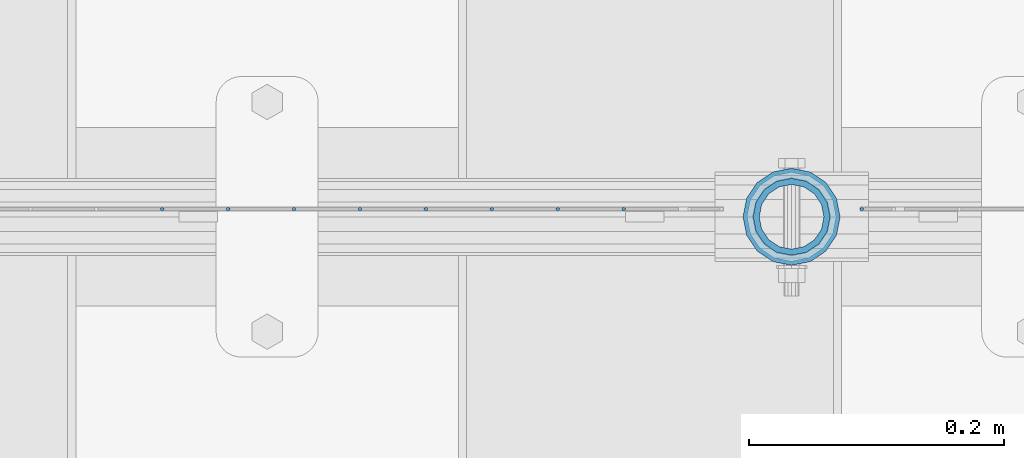
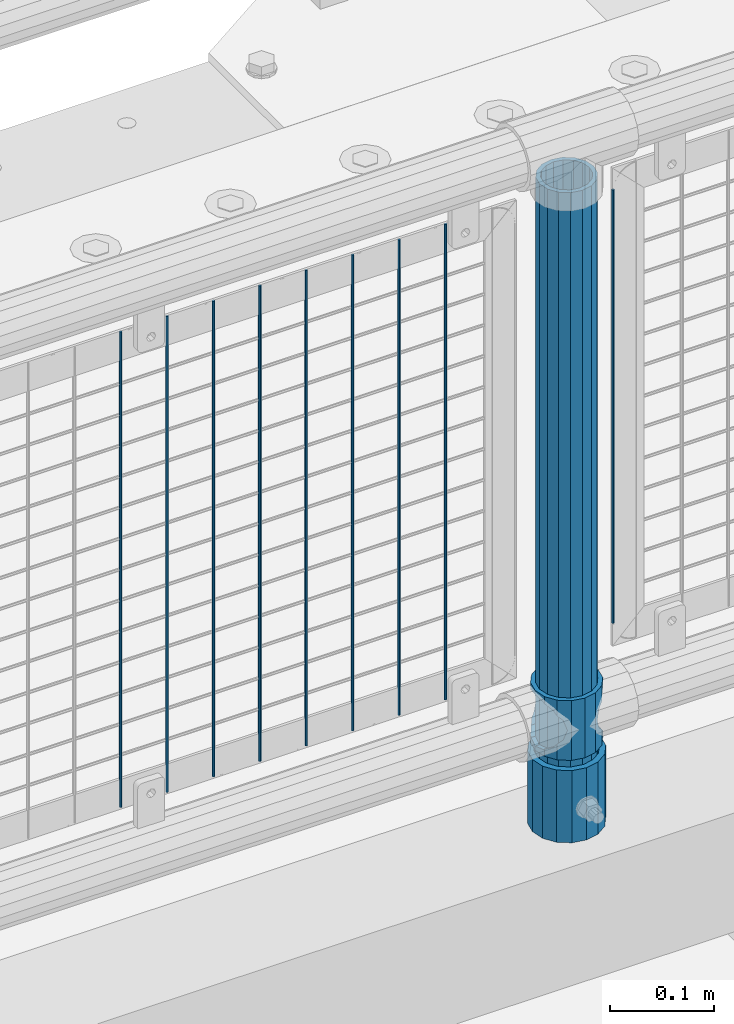
# One storey, part 70 of 193: 12 columns.
"""IFC2X3 building model written with IfcOpenShell, lengths in millimetres."""

from ifc_helpers import new_model, si_unit, frame, origin_with_axes, place, context, subcontext, project, spatial, faceted_brep, material, type_object, element, save


model = new_model("IFC2X3")

# Units and contexts
model_context = context("Model", 3, precision=1e-05, world=origin_with_axes())
body_context = subcontext(model_context, "Body", "Model", "MODEL_VIEW")
ifc_project = project(units=[si_unit("LENGTHUNIT", "METRE", prefix="MILLI"), si_unit("AREAUNIT", "SQUARE_METRE"), si_unit("VOLUMEUNIT", "CUBIC_METRE"), si_unit("MASSUNIT", "GRAM", prefix="KILO"), si_unit("TIMEUNIT", "SECOND"), si_unit("PLANEANGLEUNIT", "RADIAN"), si_unit("SOLIDANGLEUNIT", "STERADIAN"), si_unit("THERMODYNAMICTEMPERATUREUNIT", "DEGREE_CELSIUS"), si_unit("LUMINOUSINTENSITYUNIT", "LUMEN")], contexts=[model_context])

# Site, building, storey
site_placement = place(None, origin_with_axes())
site = spatial("IfcSite", under=ifc_project, at=site_placement, CompositionType="ELEMENT")
building_placement = place(site_placement, origin_with_axes())
building = spatial("IfcBuilding", under=site, at=building_placement, Name="Standard", CompositionType="ELEMENT")
storey_placement = place(building_placement, origin_with_axes())
storey = spatial("IfcBuildingStorey", under=building, at=storey_placement, Name="Undefined", CompositionType="ELEMENT", Elevation=0.0)

# Columns
ifc_material_1 = material(Name="Misc_Undefined")
column_type_1 = type_object("IfcColumnType", PredefinedType="NOTDEFINED")
column_1_placement = place(storey_placement, frame((-33539.0, 28664.5, 263.020000000001), z_axis=(-1.0, 0.0, 0.0), x_axis=(0.0, 0.0, 1.0)))
element("IfcColumn", 1, at=column_1_placement, inside=storey, type_object=column_type_1, material=ifc_material_1, context=body_context, shape_type="Brep", body=[
    faceted_brep([(56.6106908090114, 21.46069080901, -21.46069080901), (56.6106908090114, 21.46069080901, -27.1226768591041), (61.9623795176744, 13.4513226476338, -32.4743655677703), (63.1897438117172, 11.614442172282, -32.8397438117245), (63.1897438117172, 11.614442172282, -28.0397438117179), (46.7644421722801, 28.0397438117179, -11.614442172282), (46.7644421722801, 28.0397438117179, -20.0882031229849), (51.5310424080006, 24.8548033587067, -24.8548033587067), (35.1500000000015, 30.35, 0.0), (35.1499999999996, 30.3499999999985, -16.6306603983685), (23.5355578277192, 28.0397438117179, -11.614442172282), (23.5355578277192, 28.0397438117179, -20.0882031229849), (13.6893091909879, 21.46069080901, -21.46069080901), (13.6893091909879, 21.46069080901, -27.1226768591041), (18.7689575919987, 24.8548033587067, -24.8548033587067), (7.11025618828211, 11.614442172282, -28.0397438117179), (7.11025618828211, 11.614442172282, -32.8397438117245), (8.33762048232262, 13.4513226476338, -32.4743655677703), (4.79999999999961, 0.0, -30.3499999999985), (4.79999999999961, 0.0, -35.1500000000015), (7.11025618828211, -11.614442172282, -28.0397438117179), (7.11025618828211, -11.614442172282, -32.8397438117172), (13.6893091909879, -21.46069080901, -21.46069080901), (13.6893091909879, -21.46069080901, -27.1226768591114), (8.33762048232484, -13.4513226476338, -32.4743655677703), (23.5355578277191, -28.0397438117179, -11.614442172282), (23.5355578277191, -28.0397438117179, -20.0882031229812), (18.7689575919921, -24.8548033587067, -24.8548033587067), (35.1500000000015, -30.35, 0.0), (35.1499999999996, -30.3499999999985, -16.6306603983721), (46.7644421722801, -28.0397438117179, -11.614442172282), (46.7644421722801, -28.0397438117179, -20.0882031229812), (56.6106908090114, -21.46069080901, -21.46069080901), (56.6106908090114, -21.46069080901, -27.1226768591114), (51.5310424080006, -24.8548033587067, -24.8548033587067), (63.1897438117172, -11.614442172282, -28.0397438117179), (63.1897438117172, -11.614442172282, -32.8397438117172), (61.9623795176767, -13.4513226476338, -32.4743655677703), (65.4999999999997, 0.0, -30.3499999999985), (65.4999999999997, 0.0, -35.1500000000015), (0.0, -28.0397438117179, -11.614442172282), (0.0, -30.3499999999985, 0.0), (0.0, -21.46069080901, -21.46069080901), (0.0, -11.614442172282, -28.0397438117179), (0.0, 0.0, -30.3499999999985), (0.0, 11.614442172282, -28.0397438117179), (0.0, 21.46069080901, -21.46069080901), (0.0, 28.0397438117179, -11.614442172282), (0.0, 30.3499999999985, 0.0), (0.0, 28.0397438117179, 11.614442172282), (23.5355578277192, 28.0397438117179, 11.614442172282), (0.0, 21.46069080901, 21.46069080901), (13.6893091909879, 21.46069080901, 21.46069080901), (0.0, 11.614442172282, 28.0397438117179), (7.11025618828211, 11.614442172282, 28.0397438117179), (0.0, 0.0, 30.3499999999985), (4.79999999999961, 0.0, 30.3499999999985), (0.0, -11.614442172282, 28.0397438117179), (7.11025618828205, -11.614442172282, 28.0397438117179), (0.0, -21.46069080901, 21.46069080901), (13.6893091909879, -21.46069080901, 21.46069080901), (0.0, -28.0397438117179, 11.614442172282), (23.5355578277191, -28.0397438117179, 11.614442172282), (0.0, -32.4743655677703, 13.4513226476338), (0.0, -35.1500000000015, 0.0), (70.2999999999993, -35.1500000000015, 0.0), (70.2999999999993, -32.4743655677703, 13.4513226476338), (0.0, 13.4513226476338, -32.4743655677703), (0.0, 24.8548033587067, -24.8548033587067), (0.0, 0.0, -35.1500000000015), (0.0, -13.4513226476338, -32.4743655677703), (0.0, -24.8548033587067, -24.8548033587067), (0.0, -24.8548033587067, 24.8548033587067), (0.0, -13.4513226476338, 32.4743655677703), (0.0, 0.0, 35.1500000000015), (0.0, 13.4513226476338, 32.4743655677703), (0.0, 24.8548033587067, 24.8548033587067), (0.0, 32.4743655677703, 13.4513226476338), (0.0, 35.1500000000015, 0.0), (0.0, 32.4743655677703, -13.4513226476338), (0.0, -32.4743655677703, -13.4513226476338), (70.2999999999993, 32.4743655677703, 13.4513226476338), (70.2999999999993, 35.1500000000015, 0.0), (70.2999999999993, 32.4743655677703, -13.4513226476338), (70.2999999999993, 24.8548033587067, -24.8548033587067), (70.2999999999993, 13.4513226476338, -32.4743655677703), (70.2999999999993, 0.0, -35.1500000000015), (70.2999999999993, -13.4513226476338, -32.4743655677703), (70.2999999999993, -24.8548033587067, -24.8548033587067), (70.2999999999993, -32.4743655677703, -13.4513226476338), (70.2999999999993, 28.0397438117179, 11.614442172282), (70.2999999999993, 21.46069080901, 21.46069080901), (56.6106908090114, 21.46069080901, 21.46069080901), (46.7644421722801, 28.0397438117179, 11.614442172282), (70.2999999999993, 11.614442172282, 28.0397438117179), (63.1897438117172, 11.614442172282, 28.0397438117179), (70.2999999999993, 0.0, 30.3499999999985), (65.4999999999997, 0.0, 30.3499999999985), (70.2999999999993, -11.614442172282, 28.0397438117179), (63.1897438117172, -11.614442172282, 28.0397438117179), (70.2999999999993, -21.46069080901, 21.46069080901), (56.6106908090114, -21.46069080901, 21.46069080901), (70.2999999999993, -28.0397438117179, 11.614442172282), (46.7644421722801, -28.0397438117179, 11.614442172282), (70.2999999999993, -11.614442172282, -28.0397438117179), (70.2999999999993, 0.0, -30.3499999999985), (70.2999999999993, -21.46069080901, -21.46069080901), (70.2999999999993, -28.0397438117179, -11.614442172282), (70.2999999999993, -30.3499999999985, 0.0), (70.2999999999993, 24.8548033587067, 24.8548033587067), (70.2999999999993, 13.4513226476338, 32.4743655677703), (70.2999999999993, 0.0, 35.1500000000015), (70.2999999999993, -13.4513226476338, 32.4743655677703), (70.2999999999993, -24.8548033587067, 24.8548033587067), (70.2999999999993, 30.3499999999985, 0.0), (70.2999999999993, 28.0397438117179, -11.614442172282), (70.2999999999993, 21.46069080901, -21.46069080901), (70.2999999999993, 11.614442172282, -28.0397438117179), (61.9623795176742, 13.4513226476338, 32.4743655677703), (51.5310424080006, 24.8548033587067, 24.8548033587067), (56.6106908090114, 21.46069080901, 27.1226768591077), (65.4999999999997, 0.0, 35.1500000000015), (63.1897438117172, 11.614442172282, 32.8397438117136), (63.1897438117172, -11.614442172282, 32.8397438117136), (61.9623795176767, -13.4513226476338, 32.4743655677703), (56.6106908090114, -21.46069080901, 27.1226768591041), (51.5310424080006, -24.8548033587067, 24.8548033587067), (18.7689575919921, -24.8548033587067, 24.8548033587067), (46.7644421722801, -28.0397438117179, 20.0882031229812), (35.1499999999996, -30.3499999999985, 16.6306603983685), (23.5355578277191, -28.0397438117179, 20.0882031229812), (8.33762048232512, -13.4513226476338, 32.4743655677703), (13.6893091909879, -21.46069080901, 27.1226768591041), (4.79999999999961, 0.0, 35.1500000000015), (7.11025618828205, -11.614442172282, 32.8397438117136), (7.11025618828211, 11.614442172282, 32.8397438117136), (8.3376204823229, 13.4513226476338, 32.4743655677703), (13.6893091909879, 21.46069080901, 27.1226768591077), (18.7689575919987, 24.8548033587067, 24.8548033587067), (23.5355578277192, 28.0397438117179, 20.0882031229739), (35.1499999999996, 30.3499999999985, 16.6306603983576), (46.7644421722801, 28.0397438117179, 20.0882031229739)], [[[0, 1, 2, 3, 4]], [[5, 6, 7, 1, 0]], [[8, 9, 6, 5]], [[10, 11, 9, 8]], [[12, 13, 14, 11, 10]], [[15, 16, 17, 13, 12]], [[18, 19, 16, 15]], [[20, 21, 19, 18]], [[22, 23, 24, 21, 20]], [[25, 26, 27, 23, 22]], [[28, 29, 26, 25]], [[30, 31, 29, 28]], [[32, 33, 34, 31, 30]], [[35, 36, 37, 33, 32]], [[38, 39, 36, 35]], [[4, 3, 39, 38]], [[40, 41, 28, 25]], [[42, 40, 25, 22]], [[43, 42, 22, 20]], [[44, 43, 20, 18]], [[45, 44, 18, 15]], [[46, 45, 15, 12]], [[47, 46, 12, 10]], [[48, 47, 10, 8]], [[49, 48, 8, 50]], [[51, 49, 50, 52]], [[53, 51, 52, 54]], [[55, 53, 54, 56]], [[57, 55, 56, 58]], [[59, 57, 58, 60]], [[61, 59, 60, 62]], [[41, 61, 62, 28]], [[63, 64, 65, 66]], [[17, 67, 68, 14, 13]], [[19, 69, 67, 17, 16]], [[70, 69, 19, 21, 24]], [[71, 70, 24, 23, 27]], [[63, 72, 73, 74, 75, 76, 77, 78, 79, 68, 67, 69, 70, 71, 80, 64], [40, 42, 43, 44, 45, 46, 47, 48, 49, 51, 53, 55, 57, 59, 61, 41]], [[78, 77, 81, 82]], [[79, 78, 82, 83]], [[14, 68, 79, 83, 84, 7, 6, 9, 11]], [[84, 85, 2, 1, 7]], [[85, 86, 39, 3, 2]], [[37, 87, 88, 34, 33]], [[39, 86, 87, 37, 36]], [[34, 88, 89, 80, 71, 27, 26, 29, 31]], [[64, 80, 89, 65]], [[90, 91, 92, 93]], [[91, 94, 95, 92]], [[94, 96, 97, 95]], [[96, 98, 99, 97]], [[98, 100, 101, 99]], [[100, 102, 103, 101]], [[104, 105, 38, 35]], [[106, 104, 35, 32]], [[107, 106, 32, 30]], [[108, 107, 30, 28]], [[102, 108, 28, 103]], [[88, 87, 86, 85, 84, 83, 82, 81, 109, 110, 111, 112, 113, 66, 65, 89], [100, 98, 96, 94, 91, 90, 114, 115, 116, 117, 105, 104, 106, 107, 108, 102]], [[118, 110, 109, 119, 120]], [[121, 111, 110, 118, 122]], [[112, 111, 121, 123, 124]], [[113, 112, 124, 125, 126]], [[127, 72, 63, 66, 113, 126, 128, 129, 130]], [[131, 73, 72, 127, 132]], [[133, 74, 73, 131, 134]], [[75, 74, 133, 135, 136]], [[76, 75, 136, 137, 138]], [[119, 109, 81, 77, 76, 138, 139, 140, 141]], [[92, 120, 119, 141, 93]], [[95, 122, 118, 120, 92]], [[97, 121, 122, 95]], [[99, 123, 121, 97]], [[101, 125, 124, 123, 99]], [[103, 128, 126, 125, 101]], [[28, 129, 128, 103]], [[62, 130, 129, 28]], [[60, 132, 127, 130, 62]], [[58, 134, 131, 132, 60]], [[56, 133, 134, 58]], [[54, 135, 133, 56]], [[52, 137, 136, 135, 54]], [[50, 139, 138, 137, 52]], [[8, 140, 139, 50]], [[93, 141, 140, 8]], [[114, 90, 93, 8]], [[115, 114, 8, 5]], [[116, 115, 5, 0]], [[117, 116, 0, 4]], [[105, 117, 4, 38]]]),
])
ifc_material_2 = material()
column_type_2 = type_object("IfcColumnType", PredefinedType="NOTDEFINED")
column_2_placement = place(storey_placement, frame((-33539.0, 28664.5, 168.02), z_axis=(-1.0, 0.0, 0.0), x_axis=(0.0, 0.0, 1.0)))
element("IfcColumn", 2, at=column_2_placement, inside=storey, type_object=column_type_2, material=ifc_material_2, context=body_context, shape_type="Brep", body=[
    faceted_brep([(0.0, -25.3499999999985, 0.0), (0.0, -23.4203461491597, 9.70102501045403), (760.0, -23.4203461491597, 9.70102501045403), (760.0, -25.3499999999985, 0.0), (0.0, -17.9251569030785, 17.9251569030785), (760.0, -17.9251569030785, 17.9251569030785), (0.0, -9.70102501045403, 23.4203461491597), (760.0, -9.70102501045403, 23.4203461491597), (0.0, 0.0, 25.3499999999985), (760.0, 0.0, 25.3499999999985), (0.0, 9.70102501045403, 23.4203461491597), (760.0, 9.70102501045403, 23.4203461491597), (0.0, 17.9251569030785, 17.9251569030785), (760.0, 17.9251569030785, 17.9251569030785), (0.0, 23.4203461491597, 9.70102501045403), (760.0, 23.4203461491597, 9.70102501045403), (0.0, 25.3499999999985, 0.0), (760.0, 25.3499999999985, 0.0), (0.0, 23.4203461491597, -9.70102501045403), (760.0, 23.4203461491597, -9.70102501045403), (0.0, 17.9251569030785, -17.9251569030785), (760.0, 17.9251569030785, -17.9251569030785), (0.0, 9.70102501045403, -23.4203461491597), (760.0, 9.70102501045403, -23.4203461491597), (0.0, 0.0, -25.3499999999985), (760.0, 0.0, -25.3499999999985), (0.0, -9.70102501045403, -23.4203461491597), (760.0, -9.70102501045403, -23.4203461491597), (0.0, -17.9251569030785, -17.9251569030785), (760.0, -17.9251569030785, -17.9251569030785), (0.0, -23.4203461491597, -9.70102501045403), (760.0, -23.4203461491597, -9.70102501045403), (0.0, -30.1500000000015, 0.0), (0.0, -27.8549679052157, -11.5379054858058), (760.0, -27.8549679052157, -11.5379054858058), (760.0, -30.1500000000015, 0.0), (0.0, -21.3192694527752, -21.3192694527752), (760.0, -21.3192694527752, -21.3192694527752), (0.0, -11.5379054858058, -27.8549679052157), (760.0, -11.5379054858058, -27.8549679052157), (0.0, 0.0, -30.1500000000015), (760.0, 0.0, -30.1500000000015), (0.0, 11.5379054858058, -27.8549679052157), (760.0, 11.5379054858058, -27.8549679052157), (0.0, 21.3192694527752, -21.3192694527752), (760.0, 21.3192694527752, -21.3192694527752), (0.0, 27.8549679052157, -11.5379054858058), (760.0, 27.8549679052157, -11.5379054858058), (0.0, 30.1500000000015, 0.0), (760.0, 30.1500000000015, 0.0), (0.0, 27.8549679052157, 11.5379054858058), (760.0, 27.8549679052157, 11.5379054858058), (0.0, 21.3192694527752, 21.3192694527752), (760.0, 21.3192694527752, 21.3192694527752), (0.0, 11.5379054858058, 27.8549679052157), (760.0, 11.5379054858058, 27.8549679052157), (0.0, 0.0, 30.1500000000015), (760.0, 0.0, 30.1500000000015), (0.0, -11.5379054858058, 27.8549679052157), (760.0, -11.5379054858058, 27.8549679052157), (0.0, -21.3192694527752, 21.3192694527752), (760.0, -21.3192694527752, 21.3192694527752), (0.0, -27.8549679052157, 11.5379054858058), (760.0, -27.8549679052157, 11.5379054858058)], [[[0, 1, 2, 3]], [[1, 4, 5, 2]], [[4, 6, 7, 5]], [[6, 8, 9, 7]], [[8, 10, 11, 9]], [[10, 12, 13, 11]], [[12, 14, 15, 13]], [[14, 16, 17, 15]], [[16, 18, 19, 17]], [[18, 20, 21, 19]], [[20, 22, 23, 21]], [[22, 24, 25, 23]], [[24, 26, 27, 25]], [[26, 28, 29, 27]], [[28, 30, 31, 29]], [[30, 0, 3, 31]], [[32, 33, 34, 35]], [[33, 36, 37, 34]], [[36, 38, 39, 37]], [[38, 40, 41, 39]], [[40, 42, 43, 41]], [[42, 44, 45, 43]], [[44, 46, 47, 45]], [[46, 48, 49, 47]], [[48, 50, 51, 49]], [[50, 52, 53, 51]], [[52, 54, 55, 53]], [[54, 56, 57, 55]], [[56, 58, 59, 57]], [[58, 60, 61, 59]], [[60, 62, 63, 61]], [[62, 32, 35, 63]], [[37, 39, 41, 43, 45, 47, 49, 51, 53, 55, 57, 59, 61, 63, 35, 34], [5, 7, 9, 11, 13, 15, 17, 19, 21, 23, 25, 27, 29, 31, 3, 2]], [[62, 60, 58, 56, 54, 52, 50, 48, 46, 44, 42, 40, 38, 36, 33, 32], [30, 28, 26, 24, 22, 20, 18, 16, 14, 12, 10, 8, 6, 4, 1, 0]]]),
])
column_type_3 = type_object("IfcColumnType", PredefinedType="NOTDEFINED")
column_3_placement = place(storey_placement, frame((-33539.0, 28664.5, 168.02), z_axis=(0.0, 1.0, 0.0), x_axis=(0.0, 0.0, 1.0)))
element("IfcColumn", 3, at=column_3_placement, inside=storey, type_object=column_type_3, material=ifc_material_2, context=body_context, shape_type="Brep", body=[
    faceted_brep([(0.0, -31.75, 0.0), (0.0, -29.3331751572332, 12.1501989775934), (85.0, -29.3331751572332, 12.1501989775934), (85.0, -31.75, 0.0), (0.0, -22.4506403026717, 22.4506403026717), (85.0, -22.4506403026717, 22.4506403026717), (0.0, -12.1501989775934, 29.3331751572332), (85.0, -12.1501989775934, 29.3331751572332), (0.0, 0.0, 31.75), (85.0, 0.0, 31.75), (0.0, 12.1501989775934, 29.3331751572332), (85.0, 12.1501989775934, 29.3331751572332), (0.0, 22.4506403026717, 22.4506403026717), (85.0, 22.4506403026717, 22.4506403026717), (0.0, 29.3331751572332, 12.1501989775934), (85.0, 29.3331751572332, 12.1501989775934), (0.0, 31.75, 0.0), (85.0, 31.75, 0.0), (0.0, 29.3331751572332, -12.1501989775934), (85.0, 29.3331751572332, -12.1501989775934), (0.0, 22.4506403026717, -22.4506403026717), (85.0, 22.4506403026717, -22.4506403026717), (0.0, 12.1501989775934, -29.3331751572332), (85.0, 12.1501989775934, -29.3331751572332), (0.0, 0.0, -31.75), (85.0, 0.0, -31.75), (0.0, -12.1501989775934, -29.3331751572332), (85.0, -12.1501989775934, -29.3331751572332), (0.0, -22.4506403026717, -22.4506403026717), (85.0, -22.4506403026717, -22.4506403026717), (0.0, -29.3331751572332, -12.1501989775934), (85.0, -29.3331751572332, -12.1501989775934), (0.0, -38.0499999999993, 0.0), (0.0, -35.1536162120537, -14.5611046014928), (85.0, -35.1536162120537, -14.5611046014928), (85.0, -38.0499999999993, 0.0), (0.0, -26.9054130241493, -26.9054130241493), (85.0, -26.9054130241493, -26.9054130241493), (0.0, -14.5611046014928, -35.1536162120537), (85.0, -14.5611046014928, -35.1536162120537), (0.0, 0.0, -38.0499999999993), (85.0, 0.0, -38.0499999999993), (0.0, 14.5611046014928, -35.1536162120537), (85.0, 14.5611046014928, -35.1536162120537), (0.0, 26.9054130241493, -26.9054130241493), (85.0, 26.9054130241493, -26.9054130241493), (0.0, 35.1536162120537, -14.5611046014928), (85.0, 35.1536162120537, -14.5611046014928), (0.0, 38.0499999999993, 0.0), (85.0, 38.0499999999993, 0.0), (0.0, 35.1536162120537, 14.5611046014928), (85.0, 35.1536162120537, 14.5611046014928), (0.0, 26.9054130241493, 26.9054130241493), (85.0, 26.9054130241493, 26.9054130241493), (0.0, 14.5611046014928, 35.1536162120537), (85.0, 14.5611046014928, 35.1536162120537), (0.0, 0.0, 38.0499999999993), (85.0, 0.0, 38.0499999999993), (0.0, -14.5611046014928, 35.1536162120537), (85.0, -14.5611046014928, 35.1536162120537), (0.0, -26.9054130241493, 26.9054130241493), (85.0, -26.9054130241493, 26.9054130241493), (0.0, -35.1536162120537, 14.5611046014928), (85.0, -35.1536162120537, 14.5611046014928)], [[[0, 1, 2, 3]], [[1, 4, 5, 2]], [[4, 6, 7, 5]], [[6, 8, 9, 7]], [[8, 10, 11, 9]], [[10, 12, 13, 11]], [[12, 14, 15, 13]], [[14, 16, 17, 15]], [[16, 18, 19, 17]], [[18, 20, 21, 19]], [[20, 22, 23, 21]], [[22, 24, 25, 23]], [[24, 26, 27, 25]], [[26, 28, 29, 27]], [[28, 30, 31, 29]], [[30, 0, 3, 31]], [[32, 33, 34, 35]], [[33, 36, 37, 34]], [[36, 38, 39, 37]], [[38, 40, 41, 39]], [[40, 42, 43, 41]], [[42, 44, 45, 43]], [[44, 46, 47, 45]], [[46, 48, 49, 47]], [[48, 50, 51, 49]], [[50, 52, 53, 51]], [[52, 54, 55, 53]], [[54, 56, 57, 55]], [[56, 58, 59, 57]], [[58, 60, 61, 59]], [[60, 62, 63, 61]], [[62, 32, 35, 63]], [[37, 39, 41, 43, 45, 47, 49, 51, 53, 55, 57, 59, 61, 63, 35, 34], [5, 7, 9, 11, 13, 15, 17, 19, 21, 23, 25, 27, 29, 31, 3, 2]], [[62, 60, 58, 56, 54, 52, 50, 48, 46, 44, 42, 40, 38, 36, 33, 32], [30, 28, 26, 24, 22, 20, 18, 16, 14, 12, 10, 8, 6, 4, 1, 0]]]),
])
column_type_4 = type_object("IfcColumnType", Name="D3", PredefinedType="NOTDEFINED")
column_4_placement = place(storey_placement, frame((-33484.0, 28670.5, 378.020000000001), z_axis=(-1.0, 0.0, 0.0), x_axis=(0.0, 0.0, 1.0)))
element("IfcColumn", 4, at=column_4_placement, inside=storey, type_object=column_type_4, material=ifc_material_1, ObjectType="D3", context=body_context, shape_type="Brep", body=[
    faceted_brep([(0.0, -1.49999999999636, 3.63797880709171e-12), (0.0, -0.75, -1.29903810567669), (510.0, -0.75, -1.29903810567703), (510.0, -1.5, 0.0), (0.0, 0.75, -1.29903810567669), (510.0, 0.75, -1.29903810567703), (0.0, 1.50000000000364, 7.27595761418343e-12), (510.0, 1.5, 0.0), (0.0, 0.75, 1.29903810567669), (510.0, 0.75, 1.29903810567703), (0.0, -0.75, 1.29903810567669), (510.0, -0.75, 1.29903810567703)], [[[0, 1, 2, 3]], [[1, 4, 5, 2]], [[4, 6, 7, 5]], [[6, 8, 9, 7]], [[8, 10, 11, 9]], [[10, 0, 3, 11]], [[5, 7, 9, 11, 3, 2]], [[10, 8, 6, 4, 1, 0]]]),
])
for number, where, z_axis, x_axis in (
    (5, (-33670.66, 28670.5, 353.020000000001), (-1.0, 0.0, 0.0), (0.0, 0.0, 1.0)),
    (6, (-33722.315, 28670.5, 353.020000000001), (-1.0, 0.0, 0.0), (0.0, 0.0, 1.0)),
    (7, (-33773.97, 28670.5, 353.020000000001), (-1.0, 0.0, 0.0), (0.0, 0.0, 1.0)),
    (8, (-33825.625, 28670.5, 353.020000000001), (-1.0, 0.0, 0.0), (0.0, 0.0, 1.0)),
    (9, (-33877.28, 28670.5, 353.020000000001), (-1.0, 0.0, 0.0), (0.0, 0.0, 1.0)),
    (10, (-33928.935, 28670.5, 353.020000000001), (-1.0, 0.0, 0.0), (0.0, 0.0, 1.0)),
    (11, (-33980.59, 28670.5, 353.020000000001), (-1.0, 0.0, 0.0), (0.0, 0.0, 1.0)),
    (12, (-34032.245, 28670.5, 353.020000000001), (-1.0, 0.0, 0.0), (0.0, 0.0, 1.0)),
):
    element("IfcColumn", number, at=place(storey_placement, frame(where, z_axis=z_axis, x_axis=x_axis)), inside=storey, type_object=column_type_4, material=ifc_material_1, ObjectType="D3", context=body_context, shape_type="Brep", body=[
        faceted_brep([(0.0, -1.49999999999636, 3.63797880709171e-12), (0.0, -0.75, -1.29903810567669), (560.0, -0.75, -1.29903810567703), (560.0, -1.5, 0.0), (0.0, 0.75, -1.29903810567669), (560.0, 0.75, -1.29903810567703), (0.0, 1.50000000000364, 7.27595761418343e-12), (560.0, 1.5, 0.0), (0.0, 0.75, 1.29903810567669), (560.0, 0.75, 1.29903810567703), (0.0, -0.75, 1.29903810567669), (560.0, -0.75, 1.29903810567703)], [[[0, 1, 2, 3]], [[1, 4, 5, 2]], [[4, 6, 7, 5]], [[6, 8, 9, 7]], [[8, 10, 11, 9]], [[10, 0, 3, 11]], [[5, 7, 9, 11, 3, 2]], [[10, 8, 6, 4, 1, 0]]]),
    ])

save(model, "model.ifc")
